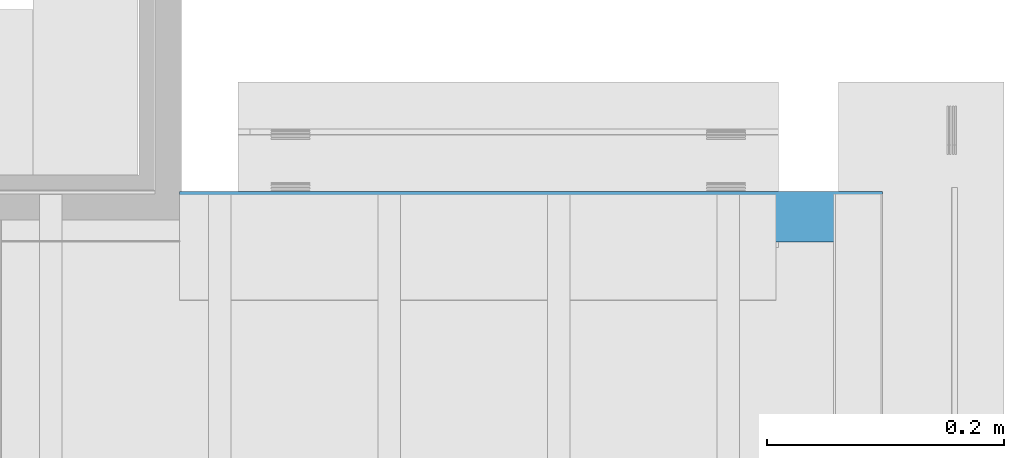
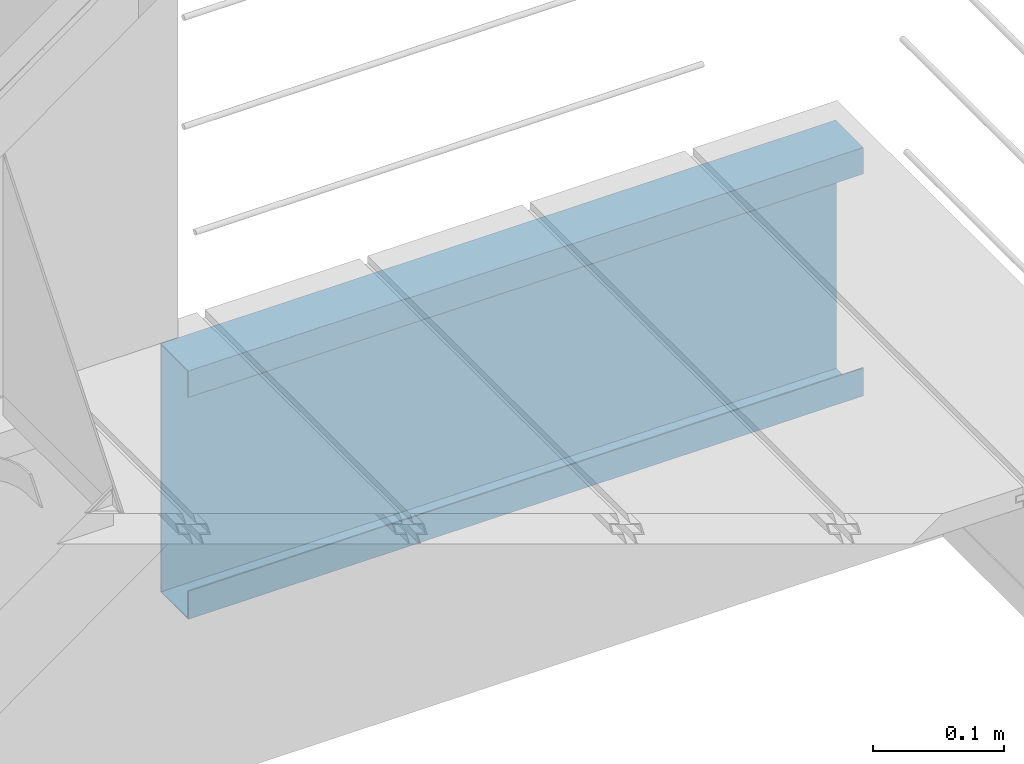
# One storey, part 26 of 33: 1 wall.
"""IFC4 building model written with IfcOpenShell, lengths in feet."""

from ifc_helpers import new_model, entity, si_unit, converted_unit, derived_unit, direction, frame, origin, place, context, subcontext, project, spatial, material, type_object, element, save


model = new_model("IFC4")

# Units and contexts
model_context = context("Model", 3, precision=0.0001, world=origin(), true_north=direction((6.12303176911189e-17, 1.0)))
body_context = subcontext(model_context, "Body", "Model", "MODEL_VIEW")
ifc_project = project(units=[converted_unit("LENGTHUNIT", "FOOT", entity("IfcRatioMeasure", 0.3048), si_unit("LENGTHUNIT", "METRE"), dimensions=[1, 0, 0, 0, 0, 0, 0]), converted_unit("AREAUNIT", "SQUARE FOOT", entity("IfcRatioMeasure", 0.09290304), si_unit("AREAUNIT", "SQUARE_METRE"), dimensions=[2, 0, 0, 0, 0, 0, 0]), converted_unit("VOLUMEUNIT", "CUBIC FOOT", entity("IfcRatioMeasure", 0.028316846592), si_unit("VOLUMEUNIT", "CUBIC_METRE"), dimensions=[3, 0, 0, 0, 0, 0, 0]), converted_unit("PLANEANGLEUNIT", "DEGREE", entity("IfcRatioMeasure", 0.0174532925199433), si_unit("PLANEANGLEUNIT", "RADIAN"), dimensions=[0, 0, 0, 0, 0, 0, 0]), si_unit("MASSUNIT", "GRAM", prefix="KILO"), derived_unit("MASSDENSITYUNIT", [(si_unit("MASSUNIT", "GRAM", prefix="KILO"), 1), (si_unit("LENGTHUNIT", "METRE"), -3)]), derived_unit("MOMENTOFINERTIAUNIT", [(si_unit("LENGTHUNIT", "METRE"), 4)]), si_unit("TIMEUNIT", "SECOND"), si_unit("FREQUENCYUNIT", "HERTZ"), si_unit("THERMODYNAMICTEMPERATUREUNIT", "DEGREE_CELSIUS"), derived_unit("THERMALTRANSMITTANCEUNIT", [(si_unit("MASSUNIT", "GRAM", prefix="KILO"), 1), (si_unit("THERMODYNAMICTEMPERATUREUNIT", "KELVIN"), -1), (si_unit("TIMEUNIT", "SECOND"), -3)]), derived_unit("VOLUMETRICFLOWRATEUNIT", [(si_unit("LENGTHUNIT", "METRE"), 3), (si_unit("TIMEUNIT", "SECOND"), -1)]), si_unit("ELECTRICCURRENTUNIT", "AMPERE"), si_unit("ELECTRICVOLTAGEUNIT", "VOLT"), si_unit("POWERUNIT", "WATT"), si_unit("FORCEUNIT", "NEWTON"), si_unit("ILLUMINANCEUNIT", "LUX"), si_unit("LUMINOUSFLUXUNIT", "LUMEN"), si_unit("LUMINOUSINTENSITYUNIT", "CANDELA"), derived_unit("USERDEFINED", [(si_unit("MASSUNIT", "GRAM", prefix="KILO"), -1), (si_unit("LENGTHUNIT", "METRE"), -2), (si_unit("TIMEUNIT", "SECOND"), 3), (si_unit("LUMINOUSFLUXUNIT", "LUMEN"), 1)]), derived_unit("LINEARVELOCITYUNIT", [(si_unit("LENGTHUNIT", "METRE"), 1), (si_unit("TIMEUNIT", "SECOND"), -1)]), si_unit("PRESSUREUNIT", "PASCAL"), derived_unit("USERDEFINED", [(si_unit("LENGTHUNIT", "METRE"), -2), (si_unit("MASSUNIT", "GRAM", prefix="KILO"), 1), (si_unit("TIMEUNIT", "SECOND"), -2)]), derived_unit("LINEARFORCEUNIT", [(si_unit("MASSUNIT", "GRAM", prefix="KILO"), 1), (si_unit("LENGTHUNIT", "METRE"), 1), (si_unit("TIMEUNIT", "SECOND"), -2), (si_unit("LENGTHUNIT", "METRE"), -1)]), derived_unit("PLANARFORCEUNIT", [(si_unit("MASSUNIT", "GRAM", prefix="KILO"), 1), (si_unit("LENGTHUNIT", "METRE"), 1), (si_unit("TIMEUNIT", "SECOND"), -2), (si_unit("LENGTHUNIT", "METRE"), -2)])], contexts=[model_context])

# Site, building, storey
site_placement = place(None, origin())
site = spatial("IfcSite", under=ifc_project, at=site_placement, CompositionType="ELEMENT")
building_placement = place(site_placement, origin())
building = spatial("IfcBuilding", under=site, at=building_placement, CompositionType="ELEMENT")
storey_placement = place(building_placement, frame((0.0, 0.0, 10.0)))
storey = spatial("IfcBuildingStorey", under=building, at=storey_placement, Name="2ND FLOOR", CompositionType="ELEMENT", Elevation=10.0000000000002)

# Wall
ifc_material = material(Name="METAL FLASHING - BLACK", Category="Materials")
wall_type = type_object("IfcWallType", Name="Generic Models 749:Generic Models 1", PredefinedType="NOTDEFINED", material=ifc_material)
wall_placement = place(storey_placement, frame((1492.34742463162, 4.60672099718356, -0.0767977711103125)))
cartesian_point_1 = entity("IfcCartesianPoint", [1.94935193376364, 0.135758623916036, 0.755056563383681])
vertex_point_1 = entity("IfcVertexPoint", cartesian_point_1)
cartesian_point_2 = entity("IfcCartesianPoint", [1.94935193376364, 0.135758623916036, 0.00210607762582171])
vertex_point_2 = entity("IfcVertexPoint", cartesian_point_2)
ifc_direction_1 = entity("IfcDirection", [0.0, 0.0, -1.0])
edge_curve_1 = entity("IfcEdgeCurve", vertex_point_1, vertex_point_2, entity("IfcTrimmedCurve", entity("IfcLine", cartesian_point_1, entity("IfcVector", ifc_direction_1, 1.0)), [cartesian_point_1], [cartesian_point_2], True, "CARTESIAN"), True)
cartesian_point_3 = entity("IfcCartesianPoint", [1.94935193376364, 0.00325520833333837, 0.00210607762581994])
vertex_point_3 = entity("IfcVertexPoint", cartesian_point_3)
ifc_direction_2 = entity("IfcDirection", [0.0, -1.0, 0.0])
edge_curve_2 = entity("IfcEdgeCurve", vertex_point_2, vertex_point_3, entity("IfcTrimmedCurve", entity("IfcLine", cartesian_point_2, entity("IfcVector", ifc_direction_2, 1.0)), [cartesian_point_2], [cartesian_point_3], True, "CARTESIAN"), True)
cartesian_point_4 = entity("IfcCartesianPoint", [1.94935193376364, 0.00325520833333748, 0.0855747487797203])
vertex_point_4 = entity("IfcVertexPoint", cartesian_point_4)
ifc_direction_3 = entity("IfcDirection", [0.0, 0.0, 1.0])
edge_curve_3 = entity("IfcEdgeCurve", vertex_point_3, vertex_point_4, entity("IfcTrimmedCurve", entity("IfcLine", cartesian_point_3, entity("IfcVector", ifc_direction_3, 1.0)), [cartesian_point_3], [cartesian_point_4], True, "CARTESIAN"), True)
cartesian_point_5 = entity("IfcCartesianPoint", [1.94935193376364, 0.0, 0.0855747487797203])
vertex_point_5 = entity("IfcVertexPoint", cartesian_point_5)
edge_curve_4 = entity("IfcEdgeCurve", vertex_point_4, vertex_point_5, entity("IfcTrimmedCurve", entity("IfcLine", cartesian_point_4, entity("IfcVector", ifc_direction_2, 1.0)), [cartesian_point_4], [cartesian_point_5], True, "CARTESIAN"), True)
cartesian_point_6 = entity("IfcCartesianPoint", [1.94935193376364, 0.0, 0.0])
vertex_point_6 = entity("IfcVertexPoint", cartesian_point_6)
edge_curve_5 = entity("IfcEdgeCurve", vertex_point_5, vertex_point_6, entity("IfcTrimmedCurve", entity("IfcLine", cartesian_point_5, entity("IfcVector", ifc_direction_1, 1.0)), [cartesian_point_5], [cartesian_point_6], True, "CARTESIAN"), True)
cartesian_point_7 = entity("IfcCartesianPoint", [1.94935193376364, 0.139013832249369, 0.0])
vertex_point_7 = entity("IfcVertexPoint", cartesian_point_7)
ifc_direction_4 = entity("IfcDirection", [0.0, 1.0, 0.0])
edge_curve_6 = entity("IfcEdgeCurve", vertex_point_6, vertex_point_7, entity("IfcTrimmedCurve", entity("IfcLine", cartesian_point_6, entity("IfcVector", ifc_direction_4, 1.0)), [cartesian_point_6], [cartesian_point_7], True, "CARTESIAN"), True)
cartesian_point_8 = entity("IfcCartesianPoint", [1.94935193376364, 0.139013832249369, 0.758311771717009])
vertex_point_8 = entity("IfcVertexPoint", cartesian_point_8)
edge_curve_7 = entity("IfcEdgeCurve", vertex_point_7, vertex_point_8, entity("IfcTrimmedCurve", entity("IfcLine", cartesian_point_7, entity("IfcVector", ifc_direction_3, 1.0)), [cartesian_point_7], [cartesian_point_8], True, "CARTESIAN"), True)
cartesian_point_9 = entity("IfcCartesianPoint", [1.94935193376364, 0.0, 0.758311771717009])
vertex_point_9 = entity("IfcVertexPoint", cartesian_point_9)
edge_curve_8 = entity("IfcEdgeCurve", vertex_point_8, vertex_point_9, entity("IfcTrimmedCurve", entity("IfcLine", cartesian_point_8, entity("IfcVector", ifc_direction_2, 1.0)), [cartesian_point_8], [cartesian_point_9], True, "CARTESIAN"), True)
cartesian_point_10 = entity("IfcCartesianPoint", [1.94935193376364, 0.0, 0.677635521770894])
vertex_point_10 = entity("IfcVertexPoint", cartesian_point_10)
edge_curve_9 = entity("IfcEdgeCurve", vertex_point_9, vertex_point_10, entity("IfcTrimmedCurve", entity("IfcLine", cartesian_point_9, entity("IfcVector", ifc_direction_1, 1.0)), [cartesian_point_9], [cartesian_point_10], True, "CARTESIAN"), True)
cartesian_point_11 = entity("IfcCartesianPoint", [1.94935193376364, 0.00325520833333304, 0.677635521770894])
vertex_point_11 = entity("IfcVertexPoint", cartesian_point_11)
edge_curve_10 = entity("IfcEdgeCurve", vertex_point_10, vertex_point_11, entity("IfcTrimmedCurve", entity("IfcLine", cartesian_point_10, entity("IfcVector", ifc_direction_4, 1.0)), [cartesian_point_10], [cartesian_point_11], True, "CARTESIAN"), True)
cartesian_point_12 = entity("IfcCartesianPoint", [1.94935193376364, 0.00325520833333304, 0.755056563383681])
vertex_point_12 = entity("IfcVertexPoint", cartesian_point_12)
edge_curve_11 = entity("IfcEdgeCurve", vertex_point_11, vertex_point_12, entity("IfcTrimmedCurve", entity("IfcLine", cartesian_point_11, entity("IfcVector", ifc_direction_3, 1.0)), [cartesian_point_11], [cartesian_point_12], True, "CARTESIAN"), True)
edge_curve_12 = entity("IfcEdgeCurve", vertex_point_12, vertex_point_1, entity("IfcTrimmedCurve", entity("IfcLine", cartesian_point_12, entity("IfcVector", ifc_direction_4, 1.0)), [cartesian_point_12], [cartesian_point_1], True, "CARTESIAN"), True)
ifc_direction_5 = entity("IfcDirection", [1.0, 0.0, 0.0])
cartesian_point_13 = entity("IfcCartesianPoint", [0.0, 0.135758623916068, 0.755056563383684])
vertex_point_13 = entity("IfcVertexPoint", cartesian_point_13)
cartesian_point_14 = entity("IfcCartesianPoint", [0.0, 0.00325520833336501, 0.755056563383684])
vertex_point_14 = entity("IfcVertexPoint", cartesian_point_14)
edge_curve_13 = entity("IfcEdgeCurve", vertex_point_13, vertex_point_14, entity("IfcTrimmedCurve", entity("IfcLine", cartesian_point_13, entity("IfcVector", ifc_direction_2, 1.0)), [cartesian_point_13], [cartesian_point_14], True, "CARTESIAN"), True)
cartesian_point_15 = entity("IfcCartesianPoint", [0.0, 0.00325520833336501, 0.677635521770897])
vertex_point_15 = entity("IfcVertexPoint", cartesian_point_15)
edge_curve_14 = entity("IfcEdgeCurve", vertex_point_14, vertex_point_15, entity("IfcTrimmedCurve", entity("IfcLine", cartesian_point_14, entity("IfcVector", ifc_direction_1, 1.0)), [cartesian_point_14], [cartesian_point_15], True, "CARTESIAN"), True)
cartesian_point_16 = entity("IfcCartesianPoint", [0.0, 0.0, 0.677635521770897])
vertex_point_16 = entity("IfcVertexPoint", cartesian_point_16)
edge_curve_15 = entity("IfcEdgeCurve", vertex_point_15, vertex_point_16, entity("IfcTrimmedCurve", entity("IfcLine", cartesian_point_15, entity("IfcVector", ifc_direction_2, 1.0)), [cartesian_point_15], [cartesian_point_16], True, "CARTESIAN"), True)
cartesian_point_17 = entity("IfcCartesianPoint", [0.0, 0.0, 0.758311771717013])
vertex_point_17 = entity("IfcVertexPoint", cartesian_point_17)
edge_curve_16 = entity("IfcEdgeCurve", vertex_point_16, vertex_point_17, entity("IfcTrimmedCurve", entity("IfcLine", cartesian_point_16, entity("IfcVector", ifc_direction_3, 1.0)), [cartesian_point_16], [cartesian_point_17], True, "CARTESIAN"), True)
cartesian_point_18 = entity("IfcCartesianPoint", [0.0, 0.139013832249401, 0.758311771717013])
vertex_point_18 = entity("IfcVertexPoint", cartesian_point_18)
edge_curve_17 = entity("IfcEdgeCurve", vertex_point_17, vertex_point_18, entity("IfcTrimmedCurve", entity("IfcLine", cartesian_point_17, entity("IfcVector", ifc_direction_4, 1.0)), [cartesian_point_17], [cartesian_point_18], True, "CARTESIAN"), True)
cartesian_point_19 = entity("IfcCartesianPoint", [0.0, 0.139013832249401, 0.0])
vertex_point_19 = entity("IfcVertexPoint", cartesian_point_19)
edge_curve_18 = entity("IfcEdgeCurve", vertex_point_18, vertex_point_19, entity("IfcTrimmedCurve", entity("IfcLine", cartesian_point_18, entity("IfcVector", ifc_direction_1, 1.0)), [cartesian_point_18], [cartesian_point_19], True, "CARTESIAN"), True)
cartesian_point_20 = entity("IfcCartesianPoint", [0.0, 0.0, 0.0])
vertex_point_20 = entity("IfcVertexPoint", cartesian_point_20)
edge_curve_19 = entity("IfcEdgeCurve", vertex_point_19, vertex_point_20, entity("IfcTrimmedCurve", entity("IfcLine", cartesian_point_19, entity("IfcVector", ifc_direction_2, 1.0)), [cartesian_point_19], [cartesian_point_20], True, "CARTESIAN"), True)
cartesian_point_21 = entity("IfcCartesianPoint", [0.0, 0.0, 0.0855747487797238])
vertex_point_21 = entity("IfcVertexPoint", cartesian_point_21)
edge_curve_20 = entity("IfcEdgeCurve", vertex_point_20, vertex_point_21, entity("IfcTrimmedCurve", entity("IfcLine", cartesian_point_20, entity("IfcVector", ifc_direction_3, 1.0)), [cartesian_point_20], [cartesian_point_21], True, "CARTESIAN"), True)
cartesian_point_22 = entity("IfcCartesianPoint", [0.0, 0.00325520833336945, 0.0855747487797238])
vertex_point_22 = entity("IfcVertexPoint", cartesian_point_22)
edge_curve_21 = entity("IfcEdgeCurve", vertex_point_21, vertex_point_22, entity("IfcTrimmedCurve", entity("IfcLine", cartesian_point_21, entity("IfcVector", ifc_direction_4, 1.0)), [cartesian_point_21], [cartesian_point_22], True, "CARTESIAN"), True)
cartesian_point_23 = entity("IfcCartesianPoint", [0.0, 0.00325520833337034, 0.00210607762582349])
vertex_point_23 = entity("IfcVertexPoint", cartesian_point_23)
edge_curve_22 = entity("IfcEdgeCurve", vertex_point_22, vertex_point_23, entity("IfcTrimmedCurve", entity("IfcLine", cartesian_point_22, entity("IfcVector", ifc_direction_1, 1.0)), [cartesian_point_22], [cartesian_point_23], True, "CARTESIAN"), True)
cartesian_point_24 = entity("IfcCartesianPoint", [0.0, 0.135758623916068, 0.00210607762582526])
vertex_point_24 = entity("IfcVertexPoint", cartesian_point_24)
edge_curve_23 = entity("IfcEdgeCurve", vertex_point_23, vertex_point_24, entity("IfcTrimmedCurve", entity("IfcLine", cartesian_point_23, entity("IfcVector", ifc_direction_4, 1.0)), [cartesian_point_23], [cartesian_point_24], True, "CARTESIAN"), True)
edge_curve_24 = entity("IfcEdgeCurve", vertex_point_24, vertex_point_13, entity("IfcTrimmedCurve", entity("IfcLine", cartesian_point_24, entity("IfcVector", ifc_direction_3, 1.0)), [cartesian_point_24], [cartesian_point_13], True, "CARTESIAN"), True)
ifc_direction_6 = entity("IfcDirection", [-1.0, 0.0, 0.0])
edge_curve_25 = entity("IfcEdgeCurve", vertex_point_13, vertex_point_1, entity("IfcTrimmedCurve", entity("IfcLine", cartesian_point_13, entity("IfcVector", ifc_direction_5, 1.0)), [cartesian_point_13], [cartesian_point_1], True, "CARTESIAN"), True)
edge_curve_26 = entity("IfcEdgeCurve", vertex_point_12, vertex_point_14, entity("IfcTrimmedCurve", entity("IfcLine", cartesian_point_14, entity("IfcVector", ifc_direction_6, 1.0)), [cartesian_point_12], [cartesian_point_14], True, "CARTESIAN"), True)
edge_curve_27 = entity("IfcEdgeCurve", vertex_point_11, vertex_point_15, entity("IfcTrimmedCurve", entity("IfcLine", cartesian_point_15, entity("IfcVector", ifc_direction_6, 1.0)), [cartesian_point_11], [cartesian_point_15], True, "CARTESIAN"), True)
edge_curve_28 = entity("IfcEdgeCurve", vertex_point_10, vertex_point_16, entity("IfcTrimmedCurve", entity("IfcLine", cartesian_point_16, entity("IfcVector", ifc_direction_6, 1.0)), [cartesian_point_10], [cartesian_point_16], True, "CARTESIAN"), True)
edge_curve_29 = entity("IfcEdgeCurve", vertex_point_9, vertex_point_17, entity("IfcTrimmedCurve", entity("IfcLine", cartesian_point_17, entity("IfcVector", ifc_direction_6, 1.0)), [cartesian_point_9], [cartesian_point_17], True, "CARTESIAN"), True)
edge_curve_30 = entity("IfcEdgeCurve", vertex_point_8, vertex_point_18, entity("IfcTrimmedCurve", entity("IfcLine", cartesian_point_18, entity("IfcVector", ifc_direction_6, 1.0)), [cartesian_point_8], [cartesian_point_18], True, "CARTESIAN"), True)
edge_curve_31 = entity("IfcEdgeCurve", vertex_point_24, vertex_point_2, entity("IfcTrimmedCurve", entity("IfcLine", cartesian_point_24, entity("IfcVector", ifc_direction_5, 1.0)), [cartesian_point_24], [cartesian_point_2], True, "CARTESIAN"), True)
edge_curve_32 = entity("IfcEdgeCurve", vertex_point_7, vertex_point_19, entity("IfcTrimmedCurve", entity("IfcLine", cartesian_point_19, entity("IfcVector", ifc_direction_6, 1.0)), [cartesian_point_7], [cartesian_point_19], True, "CARTESIAN"), True)
edge_curve_33 = entity("IfcEdgeCurve", vertex_point_6, vertex_point_20, entity("IfcTrimmedCurve", entity("IfcLine", cartesian_point_20, entity("IfcVector", ifc_direction_6, 1.0)), [cartesian_point_6], [cartesian_point_20], True, "CARTESIAN"), True)
edge_curve_34 = entity("IfcEdgeCurve", vertex_point_5, vertex_point_21, entity("IfcTrimmedCurve", entity("IfcLine", cartesian_point_21, entity("IfcVector", ifc_direction_6, 1.0)), [cartesian_point_5], [cartesian_point_21], True, "CARTESIAN"), True)
edge_curve_35 = entity("IfcEdgeCurve", vertex_point_4, vertex_point_22, entity("IfcTrimmedCurve", entity("IfcLine", cartesian_point_22, entity("IfcVector", ifc_direction_6, 1.0)), [cartesian_point_4], [cartesian_point_22], True, "CARTESIAN"), True)
edge_curve_36 = entity("IfcEdgeCurve", vertex_point_3, vertex_point_23, entity("IfcTrimmedCurve", entity("IfcLine", cartesian_point_23, entity("IfcVector", ifc_direction_6, 1.0)), [cartesian_point_3], [cartesian_point_23], True, "CARTESIAN"), True)
element("IfcWall", 1, at=wall_placement, inside=storey, type_object=wall_type, material=ifc_material, Name="Generic Models 749:Generic Models 1", ObjectType="Generic Models 749:Generic Models 1", PredefinedType="NOTDEFINED", context=body_context, shape_type="AdvancedBrep", body=[
    entity("IfcAdvancedBrep", entity("IfcClosedShell", [entity("IfcAdvancedFace", [entity("IfcFaceOuterBound", entity("IfcEdgeLoop", [entity("IfcOrientedEdge", None, None, edge_curve_1, True), entity("IfcOrientedEdge", None, None, edge_curve_2, True), entity("IfcOrientedEdge", None, None, edge_curve_3, True), entity("IfcOrientedEdge", None, None, edge_curve_4, True), entity("IfcOrientedEdge", None, None, edge_curve_5, True), entity("IfcOrientedEdge", None, None, edge_curve_6, True), entity("IfcOrientedEdge", None, None, edge_curve_7, True), entity("IfcOrientedEdge", None, None, edge_curve_8, True), entity("IfcOrientedEdge", None, None, edge_curve_9, True), entity("IfcOrientedEdge", None, None, edge_curve_10, True), entity("IfcOrientedEdge", None, None, edge_curve_11, True), entity("IfcOrientedEdge", None, None, edge_curve_12, True)]), True)], entity("IfcPlane", entity("IfcAxis2Placement3D", entity("IfcCartesianPoint", [1.94935193376364, 0.0127542562287006, 0.755056563383681]), ifc_direction_5, ifc_direction_4)), True), entity("IfcAdvancedFace", [entity("IfcFaceOuterBound", entity("IfcEdgeLoop", [entity("IfcOrientedEdge", None, None, edge_curve_13, True), entity("IfcOrientedEdge", None, None, edge_curve_14, True), entity("IfcOrientedEdge", None, None, edge_curve_15, True), entity("IfcOrientedEdge", None, None, edge_curve_16, True), entity("IfcOrientedEdge", None, None, edge_curve_17, True), entity("IfcOrientedEdge", None, None, edge_curve_18, True), entity("IfcOrientedEdge", None, None, edge_curve_19, True), entity("IfcOrientedEdge", None, None, edge_curve_20, True), entity("IfcOrientedEdge", None, None, edge_curve_21, True), entity("IfcOrientedEdge", None, None, edge_curve_22, True), entity("IfcOrientedEdge", None, None, edge_curve_23, True), entity("IfcOrientedEdge", None, None, edge_curve_24, True)]), True)], entity("IfcPlane", entity("IfcAxis2Placement3D", entity("IfcCartesianPoint", [0.0, 0.0127542562287326, 0.755056563383684]), ifc_direction_6, ifc_direction_2)), True), entity("IfcAdvancedFace", [entity("IfcFaceOuterBound", entity("IfcEdgeLoop", [entity("IfcOrientedEdge", None, None, edge_curve_13, False), entity("IfcOrientedEdge", None, None, edge_curve_25, True), entity("IfcOrientedEdge", None, None, edge_curve_12, False), entity("IfcOrientedEdge", None, None, edge_curve_26, True)]), True)], entity("IfcPlane", entity("IfcAxis2Placement3D", cartesian_point_13, ifc_direction_1, ifc_direction_5)), True), entity("IfcAdvancedFace", [entity("IfcFaceOuterBound", entity("IfcEdgeLoop", [entity("IfcOrientedEdge", None, None, edge_curve_14, False), entity("IfcOrientedEdge", None, None, edge_curve_26, False), entity("IfcOrientedEdge", None, None, edge_curve_11, False), entity("IfcOrientedEdge", None, None, edge_curve_27, True)]), True)], entity("IfcPlane", entity("IfcAxis2Placement3D", cartesian_point_14, ifc_direction_4, ifc_direction_5)), True), entity("IfcAdvancedFace", [entity("IfcFaceOuterBound", entity("IfcEdgeLoop", [entity("IfcOrientedEdge", None, None, edge_curve_15, False), entity("IfcOrientedEdge", None, None, edge_curve_27, False), entity("IfcOrientedEdge", None, None, edge_curve_10, False), entity("IfcOrientedEdge", None, None, edge_curve_28, True)]), True)], entity("IfcPlane", entity("IfcAxis2Placement3D", cartesian_point_15, ifc_direction_1, ifc_direction_5)), True), entity("IfcAdvancedFace", [entity("IfcFaceOuterBound", entity("IfcEdgeLoop", [entity("IfcOrientedEdge", None, None, edge_curve_16, False), entity("IfcOrientedEdge", None, None, edge_curve_28, False), entity("IfcOrientedEdge", None, None, edge_curve_9, False), entity("IfcOrientedEdge", None, None, edge_curve_29, True)]), True)], entity("IfcPlane", entity("IfcAxis2Placement3D", cartesian_point_16, ifc_direction_2, ifc_direction_5)), True), entity("IfcAdvancedFace", [entity("IfcFaceOuterBound", entity("IfcEdgeLoop", [entity("IfcOrientedEdge", None, None, edge_curve_17, False), entity("IfcOrientedEdge", None, None, edge_curve_29, False), entity("IfcOrientedEdge", None, None, edge_curve_8, False), entity("IfcOrientedEdge", None, None, edge_curve_30, True)]), True)], entity("IfcPlane", entity("IfcAxis2Placement3D", cartesian_point_17, ifc_direction_3, ifc_direction_5)), True), entity("IfcAdvancedFace", [entity("IfcFaceOuterBound", entity("IfcEdgeLoop", [entity("IfcOrientedEdge", None, None, edge_curve_24, False), entity("IfcOrientedEdge", None, None, edge_curve_31, True), entity("IfcOrientedEdge", None, None, edge_curve_1, False), entity("IfcOrientedEdge", None, None, edge_curve_25, False)]), True)], entity("IfcPlane", entity("IfcAxis2Placement3D", cartesian_point_24, ifc_direction_2, ifc_direction_5)), True), entity("IfcAdvancedFace", [entity("IfcFaceOuterBound", entity("IfcEdgeLoop", [entity("IfcOrientedEdge", None, None, edge_curve_18, False), entity("IfcOrientedEdge", None, None, edge_curve_30, False), entity("IfcOrientedEdge", None, None, edge_curve_7, False), entity("IfcOrientedEdge", None, None, edge_curve_32, True)]), True)], entity("IfcPlane", entity("IfcAxis2Placement3D", cartesian_point_18, ifc_direction_4, ifc_direction_5)), True), entity("IfcAdvancedFace", [entity("IfcFaceOuterBound", entity("IfcEdgeLoop", [entity("IfcOrientedEdge", None, None, edge_curve_19, False), entity("IfcOrientedEdge", None, None, edge_curve_32, False), entity("IfcOrientedEdge", None, None, edge_curve_6, False), entity("IfcOrientedEdge", None, None, edge_curve_33, True)]), True)], entity("IfcPlane", entity("IfcAxis2Placement3D", cartesian_point_19, ifc_direction_1, ifc_direction_5)), True), entity("IfcAdvancedFace", [entity("IfcFaceOuterBound", entity("IfcEdgeLoop", [entity("IfcOrientedEdge", None, None, edge_curve_20, False), entity("IfcOrientedEdge", None, None, edge_curve_33, False), entity("IfcOrientedEdge", None, None, edge_curve_5, False), entity("IfcOrientedEdge", None, None, edge_curve_34, True)]), True)], entity("IfcPlane", entity("IfcAxis2Placement3D", cartesian_point_20, ifc_direction_2, ifc_direction_5)), True), entity("IfcAdvancedFace", [entity("IfcFaceOuterBound", entity("IfcEdgeLoop", [entity("IfcOrientedEdge", None, None, edge_curve_21, False), entity("IfcOrientedEdge", None, None, edge_curve_34, False), entity("IfcOrientedEdge", None, None, edge_curve_4, False), entity("IfcOrientedEdge", None, None, edge_curve_35, True)]), True)], entity("IfcPlane", entity("IfcAxis2Placement3D", cartesian_point_21, ifc_direction_3, ifc_direction_5)), True), entity("IfcAdvancedFace", [entity("IfcFaceOuterBound", entity("IfcEdgeLoop", [entity("IfcOrientedEdge", None, None, edge_curve_22, False), entity("IfcOrientedEdge", None, None, edge_curve_35, False), entity("IfcOrientedEdge", None, None, edge_curve_3, False), entity("IfcOrientedEdge", None, None, edge_curve_36, True)]), True)], entity("IfcPlane", entity("IfcAxis2Placement3D", cartesian_point_22, ifc_direction_4, ifc_direction_5)), True), entity("IfcAdvancedFace", [entity("IfcFaceOuterBound", entity("IfcEdgeLoop", [entity("IfcOrientedEdge", None, None, edge_curve_23, False), entity("IfcOrientedEdge", None, None, edge_curve_36, False), entity("IfcOrientedEdge", None, None, edge_curve_2, False), entity("IfcOrientedEdge", None, None, edge_curve_31, False)]), True)], entity("IfcPlane", entity("IfcAxis2Placement3D", cartesian_point_23, ifc_direction_3, ifc_direction_5)), True)])),
])

save(model, "model.ifc")
